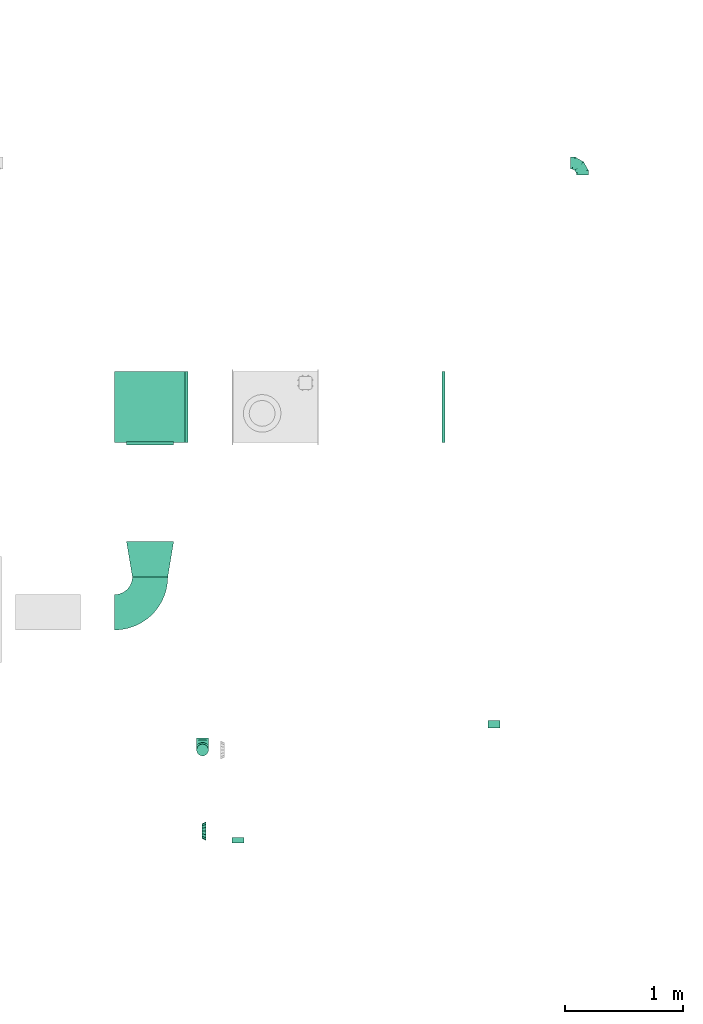
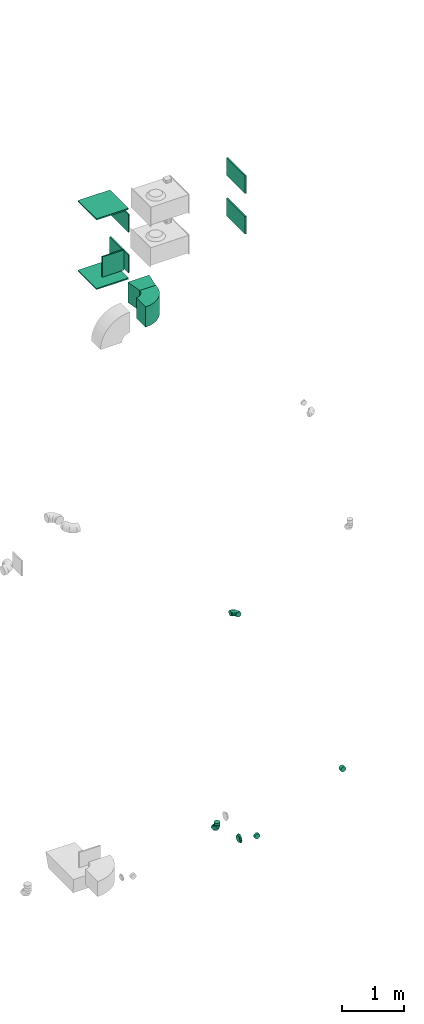
# One storey, part 15 of 44: 15 flow fittings.
"""IFC2X3 building model written with IfcOpenShell, lengths in millimetres."""

from ifc_helpers import new_model, entity, si_unit, converted_unit, derived_unit, direction, frame, frame_2d, origin, origin_2d_with_axis, place, context, subcontext, project, spatial, polyline, circle_curve, parameter, trimmed, segment, composite_curve, rectangle, outline, extrude, faceted_brep, source, transform, mapped, material, type_object, type_shapes, element, save


model = new_model("IFC2X3")

# Units and contexts
model_context = context("Model", 3, precision=0.01, world=origin(), true_north=direction((6.12303176911189e-17, 1.0)))
body_context = subcontext(model_context, "Body", "Model", "MODEL_VIEW")
ifc_project = project(units=[si_unit("LENGTHUNIT", "METRE", prefix="MILLI"), si_unit("AREAUNIT", "SQUARE_METRE"), si_unit("VOLUMEUNIT", "CUBIC_METRE"), converted_unit("PLANEANGLEUNIT", "DEGREE", entity("IfcRatioMeasure", 0.0174532925199433), si_unit("PLANEANGLEUNIT", "RADIAN"), dimensions=[0, 0, 0, 0, 0, 0, 0]), si_unit("MASSUNIT", "GRAM", prefix="KILO"), derived_unit("MASSDENSITYUNIT", [(si_unit("MASSUNIT", "GRAM", prefix="KILO"), 1), (si_unit("LENGTHUNIT", "METRE"), -3)]), derived_unit("MOMENTOFINERTIAUNIT", [(si_unit("LENGTHUNIT", "METRE"), 4)]), si_unit("TIMEUNIT", "SECOND"), si_unit("FREQUENCYUNIT", "HERTZ"), si_unit("THERMODYNAMICTEMPERATUREUNIT", "DEGREE_CELSIUS"), derived_unit("THERMALTRANSMITTANCEUNIT", [(si_unit("MASSUNIT", "GRAM", prefix="KILO"), 1), (si_unit("THERMODYNAMICTEMPERATUREUNIT", "KELVIN"), -1), (si_unit("TIMEUNIT", "SECOND"), -3)]), derived_unit("VOLUMETRICFLOWRATEUNIT", [(si_unit("LENGTHUNIT", "METRE"), 3), (si_unit("TIMEUNIT", "SECOND"), -1)]), derived_unit("MASSFLOWRATEUNIT", [(si_unit("MASSUNIT", "GRAM", prefix="KILO"), 1), (si_unit("TIMEUNIT", "SECOND"), -1)]), derived_unit("ROTATIONALFREQUENCYUNIT", [(si_unit("TIMEUNIT", "SECOND"), -1)]), si_unit("ELECTRICCURRENTUNIT", "AMPERE"), si_unit("ELECTRICVOLTAGEUNIT", "VOLT"), si_unit("POWERUNIT", "WATT"), si_unit("FORCEUNIT", "NEWTON", prefix="KILO"), si_unit("ILLUMINANCEUNIT", "LUX"), si_unit("LUMINOUSFLUXUNIT", "LUMEN"), si_unit("LUMINOUSINTENSITYUNIT", "CANDELA"), derived_unit("USERDEFINED", [(si_unit("MASSUNIT", "GRAM", prefix="KILO"), -1), (si_unit("LENGTHUNIT", "METRE"), -2), (si_unit("TIMEUNIT", "SECOND"), 3), (si_unit("LUMINOUSFLUXUNIT", "LUMEN"), 1)]), derived_unit("LINEARVELOCITYUNIT", [(si_unit("LENGTHUNIT", "METRE"), 1), (si_unit("TIMEUNIT", "SECOND"), -1)]), si_unit("PRESSUREUNIT", "PASCAL"), derived_unit("USERDEFINED", [(si_unit("LENGTHUNIT", "METRE"), -2), (si_unit("MASSUNIT", "GRAM", prefix="KILO"), 1), (si_unit("TIMEUNIT", "SECOND"), -2)]), derived_unit("LINEARFORCEUNIT", [(si_unit("MASSUNIT", "GRAM", prefix="KILO"), 1), (si_unit("LENGTHUNIT", "METRE"), 1), (si_unit("TIMEUNIT", "SECOND"), -2), (si_unit("LENGTHUNIT", "METRE"), -1)]), derived_unit("PLANARFORCEUNIT", [(si_unit("MASSUNIT", "GRAM", prefix="KILO"), 1), (si_unit("LENGTHUNIT", "METRE"), 1), (si_unit("TIMEUNIT", "SECOND"), -2), (si_unit("LENGTHUNIT", "METRE"), -2)])], contexts=[model_context])

# Site, building, storey
site_placement = place(None, origin())
site = spatial("IfcSite", under=ifc_project, at=site_placement, CompositionType="ELEMENT")
building_placement = place(site_placement, origin())
building = spatial("IfcBuilding", under=site, at=building_placement, CompositionType="ELEMENT")
storey_placement = place(building_placement, frame((0.0, 0.0, 15900.0)))
storey = spatial("IfcBuildingStorey", under=building, at=storey_placement, CompositionType="ELEMENT", Elevation=15900.0)

# Flow fittings
ifc_material = material()
duct_fitting_type_1 = type_object("IfcDuctFittingType", PredefinedType="NOTDEFINED", material=ifc_material)
shared_shape_1 = source(origin(), body_context, "Body", "SweptSolid", [
    extrude(rectangle(XDim=26.0960000000093, YDim=400.0, at=origin_2d_with_axis()), frame((6.95, 0.0, -200.0)), (0.0, 0.0, 1.0), 400.0),
])
type_shapes(duct_fitting_type_1, [shared_shape_1])
flow_fitting_1_placement = place(storey_placement, frame((25875.03, 12664.59, 12900.0), z_axis=(-1.0, 0.0, 0.0), x_axis=(0.0, -1.0, 0.0)))
element("IfcFlowFitting", 1, at=flow_fitting_1_placement, inside=storey, type_object=duct_fitting_type_1, material=ifc_material, context=body_context, shape_type="MappedRepresentation", body=[
    mapped(shared_shape_1, transform((0.0, 0.0, 0.0), scale=1.0)),
])
duct_fitting_type_2 = type_object("IfcDuctFittingType", PredefinedType="NOTDEFINED", material=ifc_material)
shared_shape_2 = source(origin(), body_context, "Body", "SweptSolid", [
    extrude(rectangle(XDim=24.9999999999999, YDim=600.0, at=origin_2d_with_axis()), frame((12.5, 0.0, -300.0)), (0.0, 0.0, 1.0), 600.0),
])
type_shapes(duct_fitting_type_2, [shared_shape_2])
for number, where, z_axis, x_axis in (
    (2, (25875.03, 12964.59, 12500.0), (0.0, -1.0, 0.0), (0.0, 0.0, -1.0)),
    (3, (25875.03, 12964.59, 13850.0), (0.0, -1.0, 0.0), (0.0, 0.0, 1.0)),
):
    element("IfcFlowFitting", number, at=place(storey_placement, frame(where, z_axis=z_axis, x_axis=x_axis)), inside=storey, type_object=duct_fitting_type_2, material=ifc_material, context=body_context, shape_type="MappedRepresentation", body=[
        mapped(shared_shape_2, transform((0.0, 0.0, 0.0), scale=1.0)),
    ])
duct_fitting_type_3 = type_object("IfcDuctFittingType", PredefinedType="NOTDEFINED", material=ifc_material)
shared_shape_3 = source(origin(), body_context, "Body", "SweptSolid", [
    extrude(rectangle(XDim=26.0960000000005, YDim=350.0, at=origin_2d_with_axis()), frame((6.95, 0.0, -300.0)), (0.0, 0.0, 1.0), 600.0),
])
type_shapes(duct_fitting_type_3, [shared_shape_3])
for number, where, z_axis, x_axis in (
    (4, (26175.03, 12964.59, 13575.0), (0.0, 1.0, 0.0), (1.0, 0.0, 0.0)),
    (5, (28370.03, 12964.59, 13575.0), (0.0, -1.0, 0.0), (-1.0, 0.0, 0.0)),
    (6, (28370.03, 12964.59, 12775.0), (0.0, 1.0, 0.0), (-1.0, 0.0, 0.0)),
):
    element("IfcFlowFitting", number, at=place(storey_placement, frame(where, z_axis=z_axis, x_axis=x_axis)), inside=storey, type_object=duct_fitting_type_3, material=ifc_material, context=body_context, shape_type="MappedRepresentation", body=[
        mapped(shared_shape_3, transform((0.0, 0.0, 0.0), scale=1.0)),
    ])
duct_fitting_type_4 = type_object("IfcDuctFittingType", PredefinedType="NOTDEFINED", material=ifc_material)
shared_shape_4 = source(origin(), body_context, "Body", "SweptSolid", [
    extrude(rectangle(XDim=350.0, YDim=26.096, at=origin_2d_with_axis()), frame((6.95, 0.0, -300.0), z_axis=(0.0, 0.0, 1.0), x_axis=(0.0, -1.0, 0.0)), (0.0, 0.0, 1.0), 600.0),
])
type_shapes(duct_fitting_type_4, [shared_shape_4])
flow_fitting_2_placement = place(storey_placement, frame((26175.03, 12964.59, 12775.0), z_axis=(0.0, -1.0, 0.0), x_axis=(1.0, 0.0, 0.0)))
element("IfcFlowFitting", 7, at=flow_fitting_2_placement, inside=storey, type_object=duct_fitting_type_4, material=ifc_material, context=body_context, shape_type="MappedRepresentation", body=[
    mapped(shared_shape_4, transform((0.0, 0.0, 0.0), scale=1.0)),
])
duct_fitting_type_5 = type_object("IfcDuctFittingType", PredefinedType="NOTDEFINED", material=ifc_material)
shared_shape_5 = source(origin(), body_context, "Body", "SweptSolid", [
    extrude(outline(polyline([(-123.3, -172.62), (180.84, -172.62), (115.08, 221.94), (-172.62, 123.3), (-123.3, -172.62)])), frame((150.0, 0.0, -200.0), z_axis=(0.0, 0.0, 1.0), x_axis=(0.986393923832143, -0.164398987305359, 0.0)), (0.0, 0.0, 1.0), 400.0),
])
type_shapes(duct_fitting_type_5, [shared_shape_5])
flow_fitting_3_placement = place(storey_placement, frame((25875.03, 11524.99, 12900.0), z_axis=(0.0, 0.0, 1.0), x_axis=(0.0, 1.0, 0.0)))
element("IfcFlowFitting", 8, at=flow_fitting_3_placement, inside=storey, type_object=duct_fitting_type_5, material=ifc_material, context=body_context, shape_type="MappedRepresentation", body=[
    mapped(shared_shape_5, transform((0.0, 0.0, 0.0), scale=1.0)),
])
duct_fitting_type_6 = type_object("IfcDuctFittingType", PredefinedType="NOTDEFINED", material=ifc_material)
shared_shape_6 = source(origin(), body_context, "Body", "Brep", [
    faceted_brep([(-100.0, 0.0, -50.0), (-100.0, -12.94, -48.3), (-100.0, -25.0, -43.3), (-100.0, -35.36, -35.36), (-100.0, -43.3, -25.0), (-100.0, -48.3, -12.94), (-100.0, -50.0, 0.0), (-100.0, -48.3, 12.94), (-100.0, -43.3, 25.0), (-100.0, -35.36, 35.36), (-100.0, -25.0, 43.3), (-100.0, -12.94, 48.3), (-100.0, 0.0, 50.0), (-100.0, 12.94, 48.3), (-100.0, 25.0, 43.3), (-100.0, 35.36, 35.36), (-100.0, 43.3, 25.0), (-100.0, 48.3, 12.94), (-100.0, 50.0, 0.0), (-100.0, 48.3, -12.94), (-100.0, 43.3, -25.0), (-100.0, 35.36, -35.36), (-100.0, 25.0, -43.3), (-100.0, 12.94, -48.3), (-76.67, 12.94, 48.3), (-79.9, 25.0, 43.3), (-73.21, 0.0, 50.0), (-82.68, 35.36, 35.36), (-86.15, 48.3, 12.94), (-86.6, 50.0, 0.0), (-84.81, 43.3, 25.0), (-84.81, 43.3, -25.0), (-82.68, 35.36, -35.36), (-86.15, 48.3, -12.94), (-76.67, 12.94, -48.3), (-73.21, 0.0, -50.0), (-79.9, 25.0, -43.3), (-69.74, -12.94, -48.3), (-66.51, -25.0, -43.3), (-63.73, -35.36, -35.36), (-61.6, -43.3, -25.0), (-60.26, -48.3, -12.94), (-59.81, -50.0, 0.0), (-60.26, -48.3, 12.94), (-61.6, -43.3, 25.0), (-63.73, -35.36, 35.36), (-66.51, -25.0, 43.3), (-69.74, -12.94, 48.3), (-36.27, 36.27, 48.3), (-45.1, 45.1, 43.3), (-26.79, 26.79, 50.0), (-52.68, 52.68, 35.36), (-58.49, 58.49, 25.0), (-62.15, 62.15, 12.94), (-63.4, 63.4, 0.0), (-62.15, 62.15, -12.94), (-58.49, 58.49, -25.0), (-52.68, 52.68, -35.36), (-36.27, 36.27, -48.3), (-26.79, 26.79, -50.0), (-45.1, 45.1, -43.3), (-17.32, 17.32, -48.3), (-8.49, 8.49, -43.3), (-0.91, 0.91, -35.36), (4.9, -4.9, -25.0), (8.56, -8.56, -12.94), (9.81, -9.81, 0.0), (8.56, -8.56, 12.94), (4.9, -4.9, 25.0), (-0.91, 0.91, 35.36), (-8.49, 8.49, 43.3), (-17.32, 17.32, 48.3), (-12.94, 76.67, 48.3), (-25.0, 79.9, 43.3), (0.0, 73.21, 50.0), (-35.36, 82.68, 35.36), (-43.3, 84.81, 25.0), (-48.3, 86.15, 12.94), (-50.0, 86.6, 0.0), (-48.3, 86.15, -12.94), (-43.3, 84.81, -25.0), (-35.36, 82.68, -35.36), (-12.94, 76.67, -48.3), (0.0, 73.21, -50.0), (-25.0, 79.9, -43.3), (12.94, 69.74, -48.3), (25.0, 66.51, -43.3), (35.36, 63.73, -35.36), (43.3, 61.6, -25.0), (48.3, 60.26, -12.94), (50.0, 59.81, 0.0), (48.3, 60.26, 12.94), (43.3, 61.6, 25.0), (35.36, 63.73, 35.36), (25.0, 66.51, 43.3), (12.94, 69.74, 48.3), (-12.94, 100.0, -48.3), (-25.0, 100.0, -43.3), (-35.36, 100.0, -35.36), (-43.3, 100.0, -25.0), (-48.3, 100.0, -12.94), (-50.0, 100.0, 0.0), (-48.3, 100.0, 12.94), (-43.3, 100.0, 25.0), (-35.36, 100.0, 35.36), (-25.0, 100.0, 43.3), (-12.94, 100.0, 48.3), (0.0, 100.0, 50.0), (12.94, 100.0, 48.3), (25.0, 100.0, 43.3), (35.36, 100.0, 35.36), (43.3, 100.0, 25.0), (48.3, 100.0, 12.94), (50.0, 100.0, 0.0), (48.3, 100.0, -12.94), (43.3, 100.0, -25.0), (35.36, 100.0, -35.36), (25.0, 100.0, -43.3), (12.94, 100.0, -48.3), (0.0, 100.0, -50.0)], [[[0, 1, 2, 3, 4, 5, 6, 7, 8, 9, 10, 11, 12, 13, 14, 15, 16, 17, 18, 19, 20, 21, 22, 23]], [[24, 25, 14, 13]], [[26, 24, 13, 12]], [[14, 25, 27, 15]], [[28, 29, 18, 17]], [[30, 28, 17, 16]], [[15, 27, 30, 16]], [[20, 31, 32, 21]], [[33, 31, 20, 19]], [[18, 29, 33, 19]], [[34, 35, 0, 23]], [[36, 34, 23, 22]], [[32, 36, 22, 21]], [[2, 1, 37, 38]], [[3, 2, 38, 39]], [[0, 35, 37, 1]], [[5, 4, 40, 41]], [[6, 5, 41, 42]], [[3, 39, 40, 4]], [[6, 42, 43, 7]], [[7, 43, 44, 8]], [[8, 44, 45, 9]], [[10, 46, 47, 11]], [[11, 47, 26, 12]], [[10, 9, 45, 46]], [[48, 49, 25, 24]], [[50, 48, 24, 26]], [[27, 25, 49, 51]], [[52, 53, 28, 30]], [[51, 52, 30, 27]], [[29, 28, 53, 54]], [[55, 56, 31, 33]], [[54, 55, 33, 29]], [[57, 32, 31, 56]], [[58, 59, 35, 34]], [[60, 58, 34, 36]], [[57, 60, 36, 32]], [[37, 35, 59, 61]], [[38, 37, 61, 62]], [[39, 38, 62, 63]], [[41, 40, 64, 65]], [[42, 41, 65, 66]], [[63, 64, 40, 39]], [[43, 42, 66, 67]], [[44, 43, 67, 68]], [[68, 69, 45, 44]], [[46, 45, 69, 70]], [[47, 46, 70, 71]], [[26, 47, 71, 50]], [[72, 73, 49, 48]], [[74, 72, 48, 50]], [[51, 49, 73, 75]], [[76, 77, 53, 52]], [[75, 76, 52, 51]], [[54, 53, 77, 78]], [[79, 80, 56, 55]], [[78, 79, 55, 54]], [[81, 57, 56, 80]], [[82, 83, 59, 58]], [[84, 82, 58, 60]], [[81, 84, 60, 57]], [[61, 59, 83, 85]], [[62, 61, 85, 86]], [[63, 62, 86, 87]], [[65, 64, 88, 89]], [[66, 65, 89, 90]], [[87, 88, 64, 63]], [[67, 66, 90, 91]], [[68, 67, 91, 92]], [[92, 93, 69, 68]], [[70, 69, 93, 94]], [[71, 70, 94, 95]], [[50, 71, 95, 74]], [[96, 97, 98, 99, 100, 101, 102, 103, 104, 105, 106, 107, 108, 109, 110, 111, 112, 113, 114, 115, 116, 117, 118, 119]], [[72, 74, 107, 106]], [[73, 72, 106, 105]], [[75, 73, 105, 104]], [[77, 76, 103, 102]], [[78, 77, 102, 101]], [[75, 104, 103, 76]], [[78, 101, 100, 79]], [[79, 100, 99, 80]], [[80, 99, 98, 81]], [[96, 119, 83, 82]], [[97, 96, 82, 84]], [[84, 81, 98, 97]], [[83, 119, 118, 85]], [[85, 118, 117, 86]], [[86, 117, 116, 87]], [[88, 115, 114, 89]], [[89, 114, 113, 90]], [[87, 116, 115, 88]], [[91, 90, 113, 112]], [[92, 91, 112, 111]], [[93, 92, 111, 110]], [[95, 94, 109, 108]], [[74, 95, 108, 107]], [[110, 109, 94, 93]]]),
])
type_shapes(duct_fitting_type_6, [shared_shape_6])
for number, where, z_axis, x_axis in (
    (9, (29539.48, 15032.9, 3300.5), (0.0, 0.0, 1.0), (0.0, 1.0, 0.0)),
    (10, (26319.53, 10057.12, 3140.0), (-1.0, 0.0, 0.0), (0.0, -1.0, 0.0)),
):
    element("IfcFlowFitting", number, at=place(storey_placement, frame(where, z_axis=z_axis, x_axis=x_axis)), inside=storey, type_object=duct_fitting_type_6, material=ifc_material, context=body_context, shape_type="MappedRepresentation", body=[
        mapped(shared_shape_6, transform((0.0, 0.0, 0.0), scale=1.0)),
    ])
duct_fitting_type_7 = type_object("IfcDuctFittingType", PredefinedType="NOTDEFINED", material=ifc_material)
shared_shape_7 = source(origin(), body_context, "Body", "Brep", [
    faceted_brep([(20.0, 12.94, -48.3), (20.0, 25.0, -43.3), (20.0, 35.36, -35.36), (20.0, 43.3, -25.0), (20.0, 48.3, -12.94), (20.0, 50.0, 0.0), (20.0, 48.3, 12.94), (20.0, 43.3, 25.0), (20.0, 35.36, 35.36), (20.0, 25.0, 43.3), (20.0, 12.94, 48.3), (20.0, 0.0, 50.0), (20.0, -12.94, 48.3), (20.0, -25.0, 43.3), (20.0, -35.36, 35.36), (20.0, -43.3, 25.0), (20.0, -48.3, 12.94), (20.0, -50.0, 0.0), (20.0, -48.3, -12.94), (20.0, -43.3, -25.0), (20.0, -35.36, -35.36), (20.0, -25.0, -43.3), (20.0, -12.94, -48.3), (20.0, 0.0, -50.0), (0.0, 0.0, 50.0), (0.0, 12.94, 48.3), (-23.65, 12.94, 48.3), (-23.65, 0.0, 50.0), (0.0, 25.0, 43.3), (-23.65, 25.0, 43.3), (0.0, 35.36, 35.36), (-23.65, 35.36, 35.36), (0.0, 43.3, 25.0), (0.0, 48.3, 12.94), (-23.65, 48.3, 12.94), (-23.65, 43.3, 25.0), (0.0, 50.0, 0.0), (-23.65, 50.0, 0.0), (0.0, 48.3, -12.94), (-23.65, 48.3, -12.94), (0.0, 43.3, -25.0), (-23.65, 43.3, -25.0), (0.0, 35.36, -35.36), (-23.65, 35.36, -35.36), (0.0, 25.0, -43.3), (0.0, 12.94, -48.3), (-23.65, 12.94, -48.3), (-23.65, 25.0, -43.3), (0.0, 0.0, -50.0), (-23.65, 0.0, -50.0), (0.0, -12.94, -48.3), (-23.65, -12.94, -48.3), (0.0, -25.0, -43.3), (-23.65, -25.0, -43.3), (0.0, -35.36, -35.36), (-23.65, -35.36, -35.36), (0.0, -43.3, -25.0), (0.0, -48.3, -12.94), (-23.65, -48.3, -12.94), (-23.65, -43.3, -25.0), (0.0, -50.0, 0.0), (-23.65, -50.0, 0.0), (0.0, -48.3, 12.94), (-23.65, -48.3, 12.94), (0.0, -43.3, 25.0), (-23.65, -43.3, 25.0), (0.0, -35.36, 35.36), (-23.65, -35.36, 35.36), (0.0, -25.0, 43.3), (0.0, -12.94, 48.3), (-23.65, -12.94, 48.3), (-23.65, -25.0, 43.3)], [[[0, 1, 2, 3, 4, 5, 6, 7, 8, 9, 10, 11, 12, 13, 14, 15, 16, 17, 18, 19, 20, 21, 22, 23]], [[24, 11, 10, 25, 26, 27]], [[25, 10, 9, 28, 29, 26]], [[28, 9, 8, 30, 31, 29]], [[32, 7, 6, 33, 34, 35]], [[33, 6, 5, 36, 37, 34]], [[30, 8, 7, 32, 35, 31]], [[36, 5, 4, 38, 39, 37]], [[38, 4, 3, 40, 41, 39]], [[40, 3, 2, 42, 43, 41]], [[44, 1, 0, 45, 46, 47]], [[45, 0, 23, 48, 49, 46]], [[42, 2, 1, 44, 47, 43]], [[48, 23, 22, 50, 51, 49]], [[50, 22, 21, 52, 53, 51]], [[52, 21, 20, 54, 55, 53]], [[56, 19, 18, 57, 58, 59]], [[57, 18, 17, 60, 61, 58]], [[54, 20, 19, 56, 59, 55]], [[60, 17, 16, 62, 63, 61]], [[62, 16, 15, 64, 65, 63]], [[64, 15, 14, 66, 67, 65]], [[68, 13, 12, 69, 70, 71]], [[69, 12, 11, 24, 27, 70]], [[66, 14, 13, 68, 71, 67]], [[49, 51, 53, 55, 59, 58, 61, 63, 65, 67, 71, 70, 27, 26, 29, 31, 35, 34, 37, 39, 41, 43, 47, 46]]]),
])
type_shapes(duct_fitting_type_7, [shared_shape_7])
flow_fitting_4_placement = place(storey_placement, frame((26620.04, 9290.12, 3375.0), z_axis=(0.0, 0.0, -1.0), x_axis=(0.0, -1.0, 0.0)))
element("IfcFlowFitting", 11, at=flow_fitting_4_placement, inside=storey, type_object=duct_fitting_type_7, material=ifc_material, context=body_context, shape_type="MappedRepresentation", body=[
    mapped(shared_shape_7, transform((0.0, 0.0, 0.0), scale=1.0)),
])
duct_fitting_type_8 = type_object("IfcDuctFittingType", PredefinedType="NOTDEFINED", material=ifc_material)
shared_shape_8 = source(origin(), body_context, "Body", "Brep", [
    faceted_brep([(35.0, 0.0, -80.0), (35.0, 12.81, -77.45), (35.0, 30.61, -73.91), (35.0, 43.59, -65.24), (35.0, 56.57, -56.57), (35.0, 65.24, -43.59), (35.0, 73.91, -30.61), (35.0, 76.96, -15.31), (35.0, 80.0, 0.0), (35.0, 77.45, 12.81), (35.0, 73.91, 30.61), (35.0, 65.24, 43.59), (35.0, 56.57, 56.57), (35.0, 43.59, 65.24), (35.0, 30.61, 73.91), (35.0, 15.31, 76.96), (35.0, 0.0, 80.0), (35.0, -12.81, 77.45), (35.0, -30.61, 73.91), (35.0, -43.59, 65.24), (35.0, -56.57, 56.57), (35.0, -65.24, 43.59), (35.0, -73.91, 30.61), (35.0, -76.96, 15.31), (35.0, -80.0, 0.0), (35.0, -77.45, -12.81), (35.0, -73.91, -30.61), (35.0, -65.24, -43.59), (35.0, -56.57, -56.57), (35.0, -43.59, -65.24), (35.0, -30.61, -73.91), (35.0, -15.31, -76.96), (0.0, -23.92, -57.74), (0.0, -34.06, -50.97), (0.0, -44.19, -44.19), (0.0, -50.97, -34.06), (0.0, -57.74, -23.92), (0.0, -60.12, -11.96), (0.0, -62.5, 0.0), (0.0, -60.12, 11.96), (0.0, -57.74, 23.92), (0.0, -50.97, 34.06), (0.0, -44.19, 44.19), (0.0, -34.06, 50.97), (0.0, -23.92, 57.74), (0.0, -11.96, 60.12), (0.0, 0.0, 62.5), (0.0, 11.96, 60.12), (0.0, 23.92, 57.74), (0.0, 34.06, 50.97), (0.0, 44.19, 44.19), (0.0, 50.97, 34.06), (0.0, 57.74, 23.92), (0.0, 60.12, 11.96), (0.0, 62.5, 0.0), (0.0, 60.12, -11.96), (0.0, 57.74, -23.92), (0.0, 50.97, -34.06), (0.0, 44.19, -44.19), (0.0, 34.06, -50.97), (0.0, 23.92, -57.74), (0.0, 11.96, -60.12), (0.0, 0.0, -62.5), (0.0, -11.96, -60.12)], [[[0, 1, 2, 3, 4, 5, 6, 7, 8, 9, 10, 11, 12, 13, 14, 15, 16, 17, 18, 19, 20, 21, 22, 23, 24, 25, 26, 27, 28, 29, 30, 31]], [[32, 33, 34, 35, 36, 37, 38, 39, 40, 41, 42, 43, 44, 45, 46, 47, 48, 49, 50, 51, 52, 53, 54, 55, 56, 57, 58, 59, 60, 61, 62, 63]], [[10, 9, 8, 54, 53, 52]], [[11, 10, 52, 51, 50, 12]], [[48, 14, 13, 12, 50, 49]], [[46, 16, 15, 14, 48, 47]], [[18, 17, 16, 46, 45, 44]], [[19, 18, 44, 43, 42, 20]], [[40, 22, 21, 20, 42, 41]], [[38, 24, 23, 22, 40, 39]], [[26, 25, 24, 38, 37, 36]], [[27, 26, 36, 35, 34, 28]], [[32, 30, 29, 28, 34, 33]], [[62, 0, 31, 30, 32, 63]], [[2, 1, 0, 62, 61, 60]], [[3, 2, 60, 59, 58, 4]], [[56, 6, 5, 4, 58, 57]], [[54, 8, 7, 6, 56, 55]]]),
])
type_shapes(duct_fitting_type_8, [shared_shape_8])
flow_fitting_5_placement = place(storey_placement, frame((26314.84, 9370.12, 3375.0)))
element("IfcFlowFitting", 12, at=flow_fitting_5_placement, inside=storey, type_object=duct_fitting_type_8, material=ifc_material, context=body_context, shape_type="MappedRepresentation", body=[
    mapped(shared_shape_8, transform((0.0, 0.0, 0.0), scale=1.0)),
])
duct_fitting_type_9 = type_object("IfcDuctFittingType", PredefinedType="NOTDEFINED", material=ifc_material)
shared_shape_9 = source(origin(), body_context, "Body", "Brep", [
    faceted_brep([(20.0, 12.94, -48.3), (20.0, 25.0, -43.3), (20.0, 35.36, -35.36), (20.0, 43.3, -25.0), (20.0, 48.3, -12.94), (20.0, 50.0, 0.0), (20.0, 48.3, 12.94), (20.0, 43.3, 25.0), (20.0, 35.36, 35.36), (20.0, 25.0, 43.3), (20.0, 12.94, 48.3), (20.0, 0.0, 50.0), (20.0, -12.94, 48.3), (20.0, -25.0, 43.3), (20.0, -35.36, 35.36), (20.0, -43.3, 25.0), (20.0, -48.3, 12.94), (20.0, -50.0, 0.0), (20.0, -48.3, -12.94), (20.0, -43.3, -25.0), (20.0, -35.36, -35.36), (20.0, -25.0, -43.3), (20.0, -12.94, -48.3), (20.0, 0.0, -50.0), (0.0, 0.0, 50.0), (0.0, 12.94, 48.3), (-43.9, 12.94, 48.3), (-43.9, 0.0, 50.0), (0.0, 25.0, 43.3), (-43.9, 25.0, 43.3), (0.0, 35.36, 35.36), (-43.9, 35.36, 35.36), (0.0, 43.3, 25.0), (0.0, 48.3, 12.94), (-43.9, 48.3, 12.94), (-43.9, 43.3, 25.0), (0.0, 50.0, 0.0), (-43.9, 50.0, 0.0), (0.0, 48.3, -12.94), (-43.9, 48.3, -12.94), (0.0, 43.3, -25.0), (-43.9, 43.3, -25.0), (0.0, 35.36, -35.36), (-43.9, 35.36, -35.36), (0.0, 25.0, -43.3), (0.0, 12.94, -48.3), (-43.9, 12.94, -48.3), (-43.9, 25.0, -43.3), (0.0, 0.0, -50.0), (-43.9, 0.0, -50.0), (0.0, -12.94, -48.3), (-43.9, -12.94, -48.3), (0.0, -25.0, -43.3), (-43.9, -25.0, -43.3), (0.0, -35.36, -35.36), (-43.9, -35.36, -35.36), (0.0, -43.3, -25.0), (0.0, -48.3, -12.94), (-43.9, -48.3, -12.94), (-43.9, -43.3, -25.0), (0.0, -50.0, 0.0), (-43.9, -50.0, 0.0), (0.0, -48.3, 12.94), (-43.9, -48.3, 12.94), (0.0, -43.3, 25.0), (-43.9, -43.3, 25.0), (0.0, -35.36, 35.36), (-43.9, -35.36, 35.36), (0.0, -25.0, 43.3), (0.0, -12.94, 48.3), (-43.9, -12.94, 48.3), (-43.9, -25.0, 43.3)], [[[0, 1, 2, 3, 4, 5, 6, 7, 8, 9, 10, 11, 12, 13, 14, 15, 16, 17, 18, 19, 20, 21, 22, 23]], [[24, 11, 10, 25, 26, 27]], [[25, 10, 9, 28, 29, 26]], [[28, 9, 8, 30, 31, 29]], [[32, 7, 6, 33, 34, 35]], [[33, 6, 5, 36, 37, 34]], [[30, 8, 7, 32, 35, 31]], [[36, 5, 4, 38, 39, 37]], [[38, 4, 3, 40, 41, 39]], [[40, 3, 2, 42, 43, 41]], [[44, 1, 0, 45, 46, 47]], [[45, 0, 23, 48, 49, 46]], [[42, 2, 1, 44, 47, 43]], [[48, 23, 22, 50, 51, 49]], [[50, 22, 21, 52, 53, 51]], [[52, 21, 20, 54, 55, 53]], [[56, 19, 18, 57, 58, 59]], [[57, 18, 17, 60, 61, 58]], [[54, 20, 19, 56, 59, 55]], [[60, 17, 16, 62, 63, 61]], [[62, 16, 15, 64, 65, 63]], [[64, 15, 14, 66, 67, 65]], [[68, 13, 12, 69, 70, 71]], [[69, 12, 11, 24, 27, 70]], [[66, 14, 13, 68, 71, 67]], [[49, 51, 53, 55, 59, 58, 61, 63, 65, 67, 71, 70, 27, 26, 29, 31, 35, 34, 37, 39, 41, 43, 47, 46]]]),
])
type_shapes(duct_fitting_type_9, [shared_shape_9])
flow_fitting_6_placement = place(storey_placement, frame((28789.25, 10287.4, 3350.0), z_axis=(0.0, 0.0, -1.0), x_axis=(0.0, 1.0, 0.0)))
element("IfcFlowFitting", 13, at=flow_fitting_6_placement, inside=storey, type_object=duct_fitting_type_9, material=ifc_material, context=body_context, shape_type="MappedRepresentation", body=[
    mapped(shared_shape_9, transform((0.0, 0.0, 0.0), scale=1.0)),
])
duct_fitting_type_10 = type_object("IfcDuctFittingType", PredefinedType="NOTDEFINED", material=ifc_material)
shared_shape_10 = source(origin(), body_context, "Body", "Brep", [
    faceted_brep([(20.0, 0.0, -50.0), (20.0, 12.94, -48.3), (20.0, 25.0, -43.3), (20.0, 35.36, -35.36), (20.0, 43.3, -25.0), (20.0, 48.3, -12.94), (20.0, 50.0, 0.0), (20.0, 48.3, 12.94), (20.0, 43.3, 25.0), (20.0, 35.36, 35.36), (20.0, 25.0, 43.3), (20.0, 12.94, 48.3), (20.0, 0.0, 50.0), (20.0, -12.94, 48.3), (20.0, -25.0, 43.3), (20.0, -35.36, 35.36), (20.0, -43.3, 25.0), (20.0, -48.3, 12.94), (20.0, -50.0, 0.0), (20.0, -48.3, -12.94), (20.0, -43.3, -25.0), (20.0, -35.36, -35.36), (20.0, -25.0, -43.3), (20.0, -12.94, -48.3), (0.0, 0.0, 50.0), (-23.65, 0.0, 50.0), (-23.65, -12.94, 48.3), (0.0, -12.94, 48.3), (-23.65, -25.0, 43.3), (0.0, -25.0, 43.3), (0.0, -35.36, 35.36), (-23.65, -35.36, 35.36), (0.0, -43.3, 25.0), (-23.65, -43.3, 25.0), (-23.65, -48.3, 12.94), (0.0, -48.3, 12.94), (-23.65, -50.0, 0.0), (0.0, -50.0, 0.0), (-23.65, -48.3, -12.94), (0.0, -48.3, -12.94), (-23.65, -43.3, -25.0), (0.0, -43.3, -25.0), (0.0, -35.36, -35.36), (-23.65, -35.36, -35.36), (0.0, -25.0, -43.3), (-23.65, -25.0, -43.3), (-23.65, -12.94, -48.3), (0.0, -12.94, -48.3), (-23.65, 0.0, -50.0), (0.0, 0.0, -50.0), (-23.65, 12.94, -48.3), (0.0, 12.94, -48.3), (-23.65, 25.0, -43.3), (0.0, 25.0, -43.3), (0.0, 35.36, -35.36), (-23.65, 35.36, -35.36), (0.0, 43.3, -25.0), (-23.65, 43.3, -25.0), (-23.65, 48.3, -12.94), (0.0, 48.3, -12.94), (-23.65, 50.0, 0.0), (0.0, 50.0, 0.0), (-23.65, 48.3, 12.94), (0.0, 48.3, 12.94), (-23.65, 43.3, 25.0), (0.0, 43.3, 25.0), (0.0, 35.36, 35.36), (-23.65, 35.36, 35.36), (0.0, 25.0, 43.3), (-23.65, 25.0, 43.3), (-23.65, 12.94, 48.3), (0.0, 12.94, 48.3)], [[[0, 1, 2, 3, 4, 5, 6, 7, 8, 9, 10, 11, 12, 13, 14, 15, 16, 17, 18, 19, 20, 21, 22, 23]], [[13, 12, 24, 25, 26, 27]], [[14, 13, 27, 26, 28, 29]], [[30, 15, 14, 29, 28, 31]], [[17, 16, 32, 33, 34, 35]], [[18, 17, 35, 34, 36, 37]], [[32, 16, 15, 30, 31, 33]], [[19, 18, 37, 36, 38, 39]], [[20, 19, 39, 38, 40, 41]], [[42, 21, 20, 41, 40, 43]], [[23, 22, 44, 45, 46, 47]], [[0, 23, 47, 46, 48, 49]], [[44, 22, 21, 42, 43, 45]], [[1, 0, 49, 48, 50, 51]], [[2, 1, 51, 50, 52, 53]], [[54, 3, 2, 53, 52, 55]], [[5, 4, 56, 57, 58, 59]], [[6, 5, 59, 58, 60, 61]], [[56, 4, 3, 54, 55, 57]], [[7, 6, 61, 60, 62, 63]], [[8, 7, 63, 62, 64, 65]], [[66, 9, 8, 65, 64, 67]], [[11, 10, 68, 69, 70, 71]], [[12, 11, 71, 70, 25, 24]], [[68, 10, 9, 66, 67, 69]], [[46, 45, 43, 40, 38, 36, 34, 33, 31, 28, 26, 25, 70, 69, 67, 64, 62, 60, 58, 57, 55, 52, 50, 48]]]),
])
type_shapes(duct_fitting_type_10, [shared_shape_10])
flow_fitting_7_placement = place(storey_placement, frame((26319.53, 10057.12, 3270.0), z_axis=(0.0, 1.0, 0.0), x_axis=(0.0, 0.0, -1.0)))
element("IfcFlowFitting", 14, at=flow_fitting_7_placement, inside=storey, type_object=duct_fitting_type_10, material=ifc_material, context=body_context, shape_type="MappedRepresentation", body=[
    mapped(shared_shape_10, transform((0.0, 0.0, 0.0), scale=1.0)),
])
duct_fitting_type_11 = type_object("IfcDuctFittingType", PredefinedType="NOTDEFINED", material=ifc_material)
shared_shape_11 = source(origin(), body_context, "Body", "SweptSolid", [
    extrude(outline(composite_curve([segment(polyline([(-300.0, -150.0), (0.0, -150.0)]), True, "CONTINUOUS"), segment(trimmed(circle_curve(frame_2d((150.0, -150.0), x_axis=(0.0, 1.0)), 150.0), [parameter(0.0)], [parameter(90.0)], True, "PARAMETER"), False, "CONTINUOUS"), segment(polyline([(150.0, 0.0), (150.0, 300.0)]), True, "CONTINUOUS"), segment(trimmed(circle_curve(frame_2d((150.0, -150.0), x_axis=(0.0, 1.0)), 450.0), [parameter(0.0)], [parameter(90.0000000000001)], True, "PARAMETER"), True, "CONTINUOUS")], self_intersect=False)), frame((-150.0, 150.0, -200.0), z_axis=(0.0, 0.0, 1.0), x_axis=(-1.0, 0.0, 0.0)), (0.0, 0.0, 1.0), 400.0),
])
type_shapes(duct_fitting_type_11, [shared_shape_11])
flow_fitting_8_placement = place(storey_placement, frame((25875.03, 11224.99, 12900.0)))
element("IfcFlowFitting", 15, at=flow_fitting_8_placement, inside=storey, type_object=duct_fitting_type_11, material=ifc_material, context=body_context, shape_type="MappedRepresentation", body=[
    mapped(shared_shape_11, transform((0.0, 0.0, 0.0), scale=1.0)),
])

save(model, "model.ifc")
